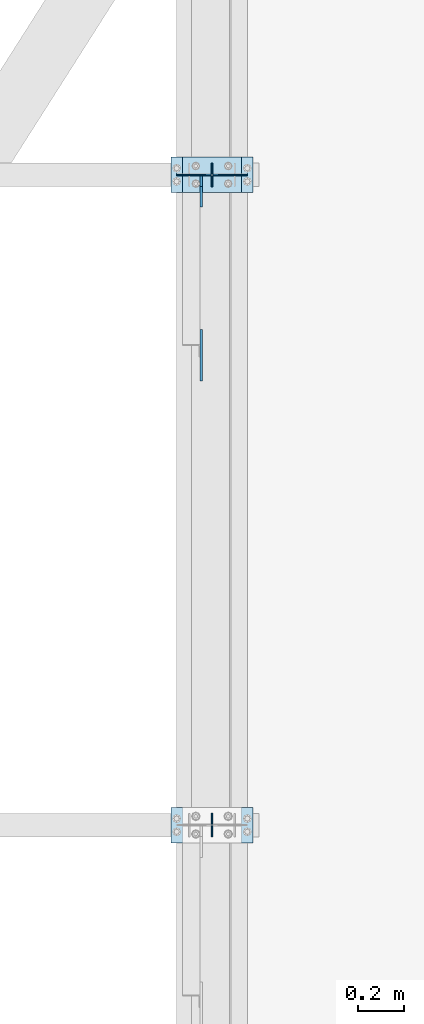
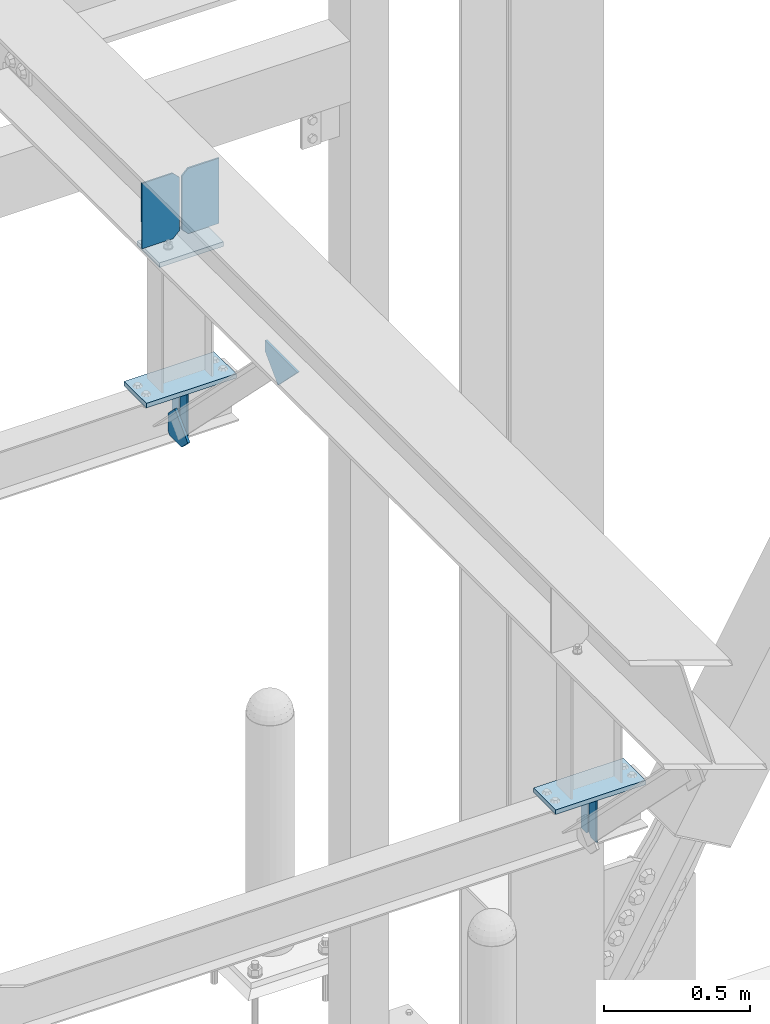
# One storey, part 3396 of 3843: 11 plates, 5 elements without a shape of their own.
"""IFC2X3 building model written with IfcOpenShell, lengths in millimetres."""

from ifc_helpers import new_model, si_unit, frame, origin_with_axes, place, context, subcontext, project, spatial, faceted_brep, material, type_object, element, aggregate, save


model = new_model("IFC2X3")

# Units and contexts
model_context = context("Model", 3, precision=1e-05, world=origin_with_axes())
body_context = subcontext(model_context, "Body", "Model", "MODEL_VIEW")
ifc_project = project(units=[si_unit("LENGTHUNIT", "METRE", prefix="MILLI"), si_unit("AREAUNIT", "SQUARE_METRE"), si_unit("VOLUMEUNIT", "CUBIC_METRE"), si_unit("MASSUNIT", "GRAM", prefix="KILO"), si_unit("TIMEUNIT", "SECOND"), si_unit("PLANEANGLEUNIT", "RADIAN"), si_unit("SOLIDANGLEUNIT", "STERADIAN"), si_unit("THERMODYNAMICTEMPERATUREUNIT", "DEGREE_CELSIUS"), si_unit("LUMINOUSINTENSITYUNIT", "LUMEN")], contexts=[model_context])

# Site, building, storey
site_placement = place(None, origin_with_axes())
site = spatial("IfcSite", under=ifc_project, at=site_placement, CompositionType="ELEMENT")
building_placement = place(site_placement, origin_with_axes())
building = spatial("IfcBuilding", under=site, at=building_placement, Name="Undefined", CompositionType="ELEMENT")
storey_placement = place(building_placement, origin_with_axes())
storey = spatial("IfcBuildingStorey", under=building, at=storey_placement, Name="Undefined", CompositionType="ELEMENT", Elevation=0.0)

# Assembly, plates
assembly_1_placement = place(storey_placement, origin_with_axes())
assembly_1 = element("IfcElementAssembly", 1, at=assembly_1_placement, inside=storey, Name="BEAM", AssemblyPlace="NOTDEFINED", PredefinedType="RIGID_FRAME")
ifc_material = material(Name="STEEL/A572-50")
plate_type_1 = type_object("IfcPlateType", PredefinedType="NOTDEFINED")
plate_1_placement = place(assembly_1_placement, frame((42062.4, 79756.0, 41495.6625), z_axis=(0.0, 0.0, -1.0), x_axis=(0.0, 1.0, 0.0)))
plate_1 = element("IfcPlate", 2, at=plate_1_placement, type_object=plate_type_1, material=ifc_material, Name="PLATE", context=body_context, shape_type="Brep", body=[
    faceted_brep([(0.0, -3.17499999999927, 0.0), (0.0, -3.17500000000291, 187.324999999997), (0.0, 3.17500000000291, 187.324999999997), (0.0, 3.17499999999927, 0.0), (34.9250001907349, -3.17500000000291, 187.324999999997), (34.9250001907349, 3.17500000000291, 187.324999999997), (47.625, -3.17500000000291, 174.625000190732), (47.625, 3.17500000000291, 174.625000190732), (47.625, -3.17499999999927, 12.6999998092651), (47.625, 3.17499999999927, 12.6999998092651), (34.9250001907349, -3.17499999999927, 0.0), (34.9250001907349, 3.17499999999927, 0.0)], [[[0, 1, 2, 3]], [[1, 4, 5, 2]], [[4, 6, 7, 5]], [[6, 8, 9, 7]], [[8, 10, 11, 9]], [[10, 0, 3, 11]], [[5, 7, 9, 11, 3, 2]], [[10, 8, 6, 4, 1, 0]]]),
])
plate_2_placement = place(assembly_1_placement, frame((42062.4, 79857.6, 41495.6625), z_axis=(0.0, 0.0, -1.0), x_axis=(0.0, -1.0, 0.0)))
plate_2 = element("IfcPlate", 3, at=plate_2_placement, type_object=plate_type_1, material=ifc_material, Name="PLATE", context=body_context, shape_type="Brep", body=[
    faceted_brep([(0.0, -3.17499999999927, 0.0), (0.0, -3.17500000000291, 187.324999999997), (0.0, 3.17500000000291, 187.324999999997), (0.0, 3.17499999999927, 0.0), (34.9250001907349, -3.17500000000291, 187.324999999997), (34.9250001907349, 3.17500000000291, 187.324999999997), (47.625, -3.17500000000291, 174.625000190732), (47.625, 3.17500000000291, 174.625000190732), (47.625, -3.17499999999927, 12.6999998092651), (47.625, 3.17499999999927, 12.6999998092651), (34.9250001907349, -3.17499999999927, 0.0), (34.9250001907349, 3.17499999999927, 0.0)], [[[0, 1, 2, 3]], [[1, 4, 5, 2]], [[4, 6, 7, 5]], [[6, 8, 9, 7]], [[8, 10, 11, 9]], [[10, 0, 3, 11]], [[5, 7, 9, 11, 3, 2]], [[10, 8, 6, 4, 1, 0]]]),
])
aggregate(assembly_1, [plate_1, plate_2])

assembly_2_placement = place(storey_placement, origin_with_axes())
assembly_2 = element("IfcElementAssembly", 4, at=assembly_2_placement, inside=storey, Name="BEAM", AssemblyPlace="NOTDEFINED", PredefinedType="RIGID_FRAME")
plate_3_placement = place(assembly_2_placement, frame((42062.4, 82562.7, 41495.6625), z_axis=(0.0, 0.0, -1.0), x_axis=(0.0, 1.0, 0.0)))
plate_3 = element("IfcPlate", 5, at=plate_3_placement, type_object=plate_type_1, material=ifc_material, Name="PLATE", context=body_context, shape_type="Brep", body=[
    faceted_brep([(0.0, -3.17499999999927, 0.0), (0.0, -3.17500000000291, 187.324999999997), (0.0, 3.17500000000291, 187.324999999997), (0.0, 3.17499999999927, 0.0), (34.9250001907349, -3.17500000000291, 187.324999999997), (34.9250001907349, 3.17500000000291, 187.324999999997), (47.625, -3.17500000000291, 174.625000190732), (47.625, 3.17500000000291, 174.625000190732), (47.625, -3.17499999999927, 12.6999998092651), (47.625, 3.17499999999927, 12.6999998092651), (34.9250001907349, -3.17499999999927, 0.0), (34.9250001907349, 3.17499999999927, 0.0)], [[[0, 1, 2, 3]], [[1, 4, 5, 2]], [[4, 6, 7, 5]], [[6, 8, 9, 7]], [[8, 10, 11, 9]], [[10, 0, 3, 11]], [[5, 7, 9, 11, 3, 2]], [[10, 8, 6, 4, 1, 0]]]),
])
plate_4_placement = place(assembly_2_placement, frame((42062.4, 82664.3, 41495.6625), z_axis=(0.0, 0.0, -1.0), x_axis=(0.0, -1.0, 0.0)))
plate_4 = element("IfcPlate", 6, at=plate_4_placement, type_object=plate_type_1, material=ifc_material, Name="PLATE", context=body_context, shape_type="Brep", body=[
    faceted_brep([(0.0, -3.17499999999927, 0.0), (0.0, -3.17500000000291, 187.324999999997), (0.0, 3.17500000000291, 187.324999999997), (0.0, 3.17499999999927, 0.0), (34.9250001907349, -3.17500000000291, 187.324999999997), (34.9250001907349, 3.17500000000291, 187.324999999997), (47.625, -3.17500000000291, 174.625000190732), (47.625, 3.17500000000291, 174.625000190732), (47.625, -3.17499999999927, 12.6999998092651), (47.625, 3.17499999999927, 12.6999998092651), (34.9250001907349, -3.17499999999927, 0.0), (34.9250001907349, 3.17499999999927, 0.0)], [[[0, 1, 2, 3]], [[1, 4, 5, 2]], [[4, 6, 7, 5]], [[6, 8, 9, 7]], [[8, 10, 11, 9]], [[10, 0, 3, 11]], [[5, 7, 9, 11, 3, 2]], [[10, 8, 6, 4, 1, 0]]]),
])

# Assembly, plate
assembly_3_placement = place(storey_placement, origin_with_axes())
assembly_3 = element("IfcElementAssembly", 7, at=assembly_3_placement, inside=storey, Name="POST", AssemblyPlace="NOTDEFINED", PredefinedType="RIGID_FRAME")
plate_type_2 = type_object("IfcPlateType", PredefinedType="NOTDEFINED")
plate_5_placement = place(assembly_3_placement, frame((41935.3999970238, 82689.6996996083, 42083.0375000006), z_axis=(0.0, -1.0, 0.0), x_axis=(1.0, 0.0, 0.0)))
plate_5 = element("IfcPlate", 8, at=plate_5_placement, type_object=plate_type_2, material=ifc_material, Name="PLATE", context=body_context, shape_type="Brep", body=[
    faceted_brep([(0.0, -9.52500000000146, 0.0), (0.0, -9.5249999999287, 152.40000000162), (0.0, 9.52500000002328, 152.40000000162), (0.0, 9.52500000000146, 0.0), (254.0, -9.5249999999287, 152.40000000162), (254.0, 9.52500000002328, 152.40000000162), (253.999999999998, -9.52500000000146, 0.0), (253.999999999998, 9.52500000000146, 0.0)], [[[0, 1, 2, 3]], [[1, 4, 5, 2]], [[4, 6, 7, 5]], [[6, 0, 3, 7]], [[5, 7, 3, 2]], [[6, 4, 1, 0]]]),
])

assembly_4_placement = place(storey_placement, origin_with_axes())
assembly_4 = element("IfcElementAssembly", 9, at=assembly_4_placement, inside=storey, Name="POST", AssemblyPlace="NOTDEFINED", PredefinedType="RIGID_FRAME")
plate_6_placement = place(assembly_4_placement, frame((42240.2, 79730.6, 41513.125), z_axis=(-1.0, 0.0, 0.0), x_axis=(0.0, 1.0, 0.0)))
plate_6 = element("IfcPlate", 10, at=plate_6_placement, type_object=plate_type_2, material=ifc_material, Name="PLATE", context=body_context, shape_type="Brep", body=[
    faceted_brep([(0.0, -9.52500000000146, 0.0), (0.0, -9.52500000000146, 355.599999999999), (0.0, 9.52500000000146, 355.599999999999), (0.0, 9.52500000000146, 0.0), (152.399999999994, -9.52500000000146, 355.599999999999), (152.399999999994, 9.52500000000146, 355.599999999999), (152.400000000001, -9.52500000000146, 0.0), (152.400000000001, 9.52500000000146, 0.0)], [[[0, 1, 2, 3]], [[1, 4, 5, 2]], [[4, 6, 7, 5]], [[6, 0, 3, 7]], [[5, 7, 3, 2]], [[6, 4, 1, 0]]]),
])
aggregate(assembly_4, [plate_6])

# Plate
plate_7_placement = place(assembly_3_placement, frame((42240.2, 82537.3, 41513.125), z_axis=(-1.0, 0.0, 0.0), x_axis=(0.0, 1.0, 0.0)))
plate_7 = element("IfcPlate", 11, at=plate_7_placement, type_object=plate_type_2, material=ifc_material, Name="PLATE", context=body_context, shape_type="Brep", body=[
    faceted_brep([(0.0, -9.52500000000146, 0.0), (0.0, -9.52500000000146, 355.599999999999), (0.0, 9.52500000000146, 355.599999999999), (0.0, 9.52500000000146, 0.0), (152.399999999994, -9.52500000000146, 355.599999999999), (152.399999999994, 9.52500000000146, 355.599999999999), (152.400000000001, -9.52500000000146, 0.0), (152.400000000001, 9.52500000000146, 0.0)], [[[0, 1, 2, 3]], [[1, 4, 5, 2]], [[4, 6, 7, 5]], [[6, 0, 3, 7]], [[5, 7, 3, 2]], [[6, 4, 1, 0]]]),
])

aggregate(assembly_3, [plate_5, plate_7])

# Assembly, plate
assembly_5_placement = place(storey_placement, origin_with_axes())
assembly_5 = element("IfcElementAssembly", 12, at=assembly_5_placement, inside=storey, Name="BEAM", AssemblyPlace="NOTDEFINED", PredefinedType="RIGID_FRAME")
plate_type_3 = type_object("IfcPlateType", PredefinedType="NOTDEFINED")
plate_8_placement = place(assembly_5_placement, frame((42016.3625, 81722.6946142168, 42101.3093631582), z_axis=(0.0, 0.707106781186548, 0.707106781186548), x_axis=(5.70000238222118e-08, 0.707106781186546, -0.707106781186546)))
plate_8 = element("IfcPlate", 13, at=plate_8_placement, type_object=plate_type_3, material=ifc_material, Name="PLATE", context=body_context, shape_type="Brep", body=[
    faceted_brep([(0.0, -4.76249999999709, 0.0), (157.726597423803, -4.76249999999709, 157.726601438866), (157.726597423803, 4.76249999999709, 157.726601438866), (0.0, 4.76249999999709, 0.0), (188.387110059113, -4.76249999999709, 127.066089584019), (188.387110059113, 4.76249999999709, 127.066089584019), (188.387111679331, -4.76249999999709, 1.09139364212751e-10), (188.387111679331, 4.76249999999709, 1.09139364212751e-10)], [[[0, 1, 2, 3]], [[1, 4, 5, 2]], [[4, 6, 7, 5]], [[6, 0, 3, 7]], [[5, 7, 3, 2]], [[6, 4, 1, 0]]]),
])

# Plate
plate_type_4 = type_object("IfcPlateType", PredefinedType="NOTDEFINED")
plate_9_placement = place(assembly_2_placement, frame((42016.3625, 82610.325, 41306.75), z_axis=(0.0, -1.0, 0.0), x_axis=(0.0, 0.0, 1.0)))
plate_9 = element("IfcPlate", 14, at=plate_9_placement, type_object=plate_type_4, material=ifc_material, Name="PLATE", context=body_context, shape_type="Brep", body=[
    faceted_brep([(0.0, -4.76250000000073, 12.6999998092651), (4.450703272596e-08, -4.76249999999709, 93.0710244828806), (4.450703272596e-08, 4.76249999999709, 93.0710244828806), (0.0, 4.76250000000073, 12.6999998092651), (43.3137807601452, -4.76249999999709, 136.384805065652), (43.3137807601452, 4.76249999999709, 136.384805065652), (133.209805202001, -4.76249999999709, 46.4887805392646), (133.209805202001, 4.76249999999709, 46.4887805392646), (86.7210245267561, -4.76249999999709, 0.0), (86.7210245267561, 4.76249999999709, 0.0), (12.6999998092651, -4.76250000000073, 0.0), (12.6999998092651, 4.76250000000073, 0.0)], [[[0, 1, 2, 3]], [[1, 4, 5, 2]], [[4, 6, 7, 5]], [[6, 8, 9, 7]], [[8, 10, 11, 9]], [[10, 0, 3, 11]], [[5, 7, 9, 11, 3, 2]], [[10, 8, 6, 4, 1, 0]]]),
])

aggregate(assembly_2, [plate_9, plate_3, plate_4])

plate_type_5 = type_object("IfcPlateType", PredefinedType="NOTDEFINED")
plate_10_placement = place(assembly_5_placement, frame((42214.8, 82614.3157317916, 42389.5718308325), z_axis=(0.0, -0.00280790599950705, -0.999996057824179), x_axis=(-1.0, 0.0, 0.0)))
plate_10 = element("IfcPlate", 15, at=plate_10_placement, type_object=plate_type_5, material=ifc_material, Name="PLATE", context=body_context, shape_type="Brep", body=[
    faceted_brep([(0.0, -3.17499999999927, 0.0), (0.0, -3.17500000007567, 273.049999997937), (0.0, 3.17499999993743, 273.049999997937), (0.0, 3.17499999999927, 0.0), (122.237500389827, -3.17500000007567, 273.049999997937), (122.237500389827, 3.17499999993743, 273.049999997937), (147.637500008357, -3.17500000006476, 247.650000379464), (147.637500008357, 3.17499999994106, 247.650000379464), (147.637500008357, -3.17500000001382, 25.3999996184648), (147.637500008357, 3.17499999999927, 25.3999996184648), (122.237500389827, -3.17500000000291, 0.0), (122.237500389827, 3.17500000000291, -7.27595761418343e-12)], [[[0, 1, 2, 3]], [[1, 4, 5, 2]], [[4, 6, 7, 5]], [[6, 8, 9, 7]], [[8, 10, 11, 9]], [[10, 0, 3, 11]], [[5, 7, 9, 11, 3, 2]], [[10, 8, 6, 4, 1, 0]]]),
])

plate_11_placement = place(assembly_5_placement, frame((41910.0, 82614.3157317916, 42389.5718308325), z_axis=(0.0, -0.00280790599950705, -0.999996057824179), x_axis=(1.0, 0.0, 0.0)))
plate_11 = element("IfcPlate", 16, at=plate_11_placement, type_object=plate_type_5, material=ifc_material, Name="PLATE", context=body_context, shape_type="Brep", body=[
    faceted_brep([(0.0, -3.17499999999927, 0.0), (0.0, -3.17500000007567, 273.049999997937), (0.0, 3.17499999993743, 273.049999997937), (0.0, 3.17499999999927, 0.0), (122.237500389827, -3.17500000007567, 273.049999997937), (122.237500389827, 3.17499999993743, 273.049999997937), (147.637500008357, -3.17500000006476, 247.650000379464), (147.637500008357, 3.17499999994106, 247.650000379464), (147.637500008357, -3.17500000001382, 25.3999996184648), (147.637500008357, 3.17499999999927, 25.3999996184648), (122.237500389827, -3.17500000000291, 0.0), (122.237500389827, 3.17500000000291, -7.27595761418343e-12)], [[[0, 1, 2, 3]], [[1, 4, 5, 2]], [[4, 6, 7, 5]], [[6, 8, 9, 7]], [[8, 10, 11, 9]], [[10, 0, 3, 11]], [[5, 7, 9, 11, 3, 2]], [[10, 8, 6, 4, 1, 0]]]),
])

aggregate(assembly_5, [plate_10, plate_11, plate_8])

save(model, "model.ifc")
